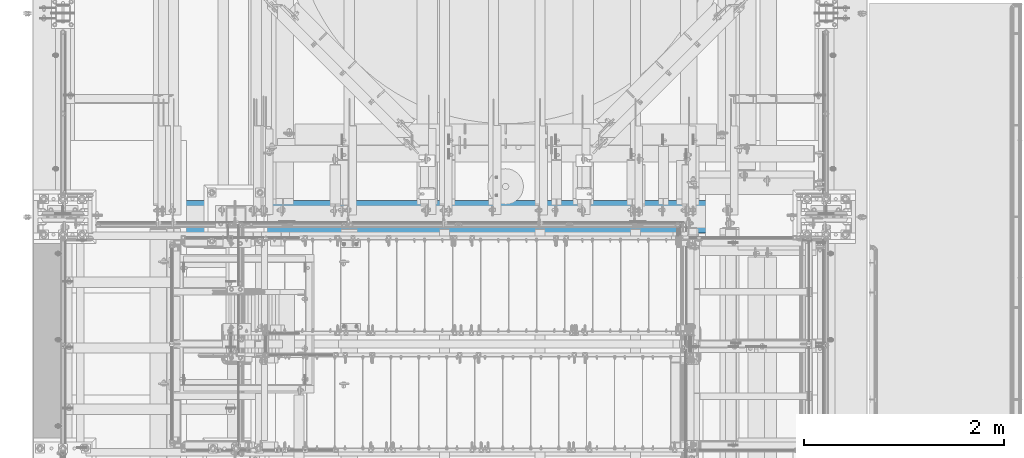
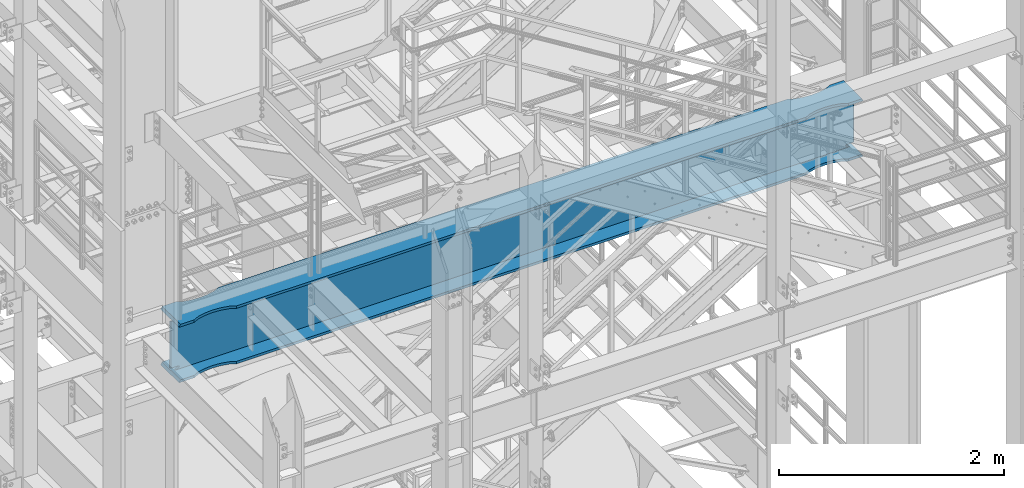
# One storey, part 980 of 1876: 1 beam, 1 element without a shape of its own.
"""IFC2X3 building model written with IfcOpenShell, lengths in millimetres."""

from ifc_helpers import new_model, si_unit, frame, origin_with_axes, place, context, subcontext, project, spatial, faceted_brep, material, type_object, element, aggregate, save


model = new_model("IFC2X3")

# Units and contexts
model_context = context("Model", 3, precision=1e-05, world=origin_with_axes())
body_context = subcontext(model_context, "Body", "Model", "MODEL_VIEW")
ifc_project = project(units=[si_unit("LENGTHUNIT", "METRE", prefix="MILLI"), si_unit("AREAUNIT", "SQUARE_METRE"), si_unit("VOLUMEUNIT", "CUBIC_METRE"), si_unit("MASSUNIT", "GRAM", prefix="KILO"), si_unit("TIMEUNIT", "SECOND"), si_unit("PLANEANGLEUNIT", "RADIAN"), si_unit("SOLIDANGLEUNIT", "STERADIAN"), si_unit("THERMODYNAMICTEMPERATUREUNIT", "DEGREE_CELSIUS"), si_unit("LUMINOUSINTENSITYUNIT", "LUMEN")], contexts=[model_context])

# Site, building, storey
site_placement = place(None, origin_with_axes())
site = spatial("IfcSite", under=ifc_project, at=site_placement, CompositionType="ELEMENT")
building_placement = place(site_placement, origin_with_axes())
building = spatial("IfcBuilding", under=site, at=building_placement, Name="Undefined", CompositionType="ELEMENT")
storey_placement = place(building_placement, origin_with_axes())
storey = spatial("IfcBuildingStorey", under=building, at=storey_placement, Name="Undefined", CompositionType="ELEMENT", Elevation=0.0)

# Assembly, beam
assembly_placement = place(storey_placement, origin_with_axes())
assembly = element("IfcElementAssembly", 1, at=assembly_placement, inside=storey, Name="BEAM", AssemblyPlace="NOTDEFINED", PredefinedType="RIGID_FRAME")
ifc_material = material(Name="STEEL/A992")
beam_type = type_object("IfcBeamType", Name="W24X146", PredefinedType="NOTDEFINED")
beam_placement = place(assembly_placement, frame((0.0, -4572.0, 12995.275), z_axis=(0.0, 0.0, 1.0), x_axis=(1.0, 0.0, 0.0)))
beam = element("IfcBeam", 2, at=beam_placement, type_object=beam_type, material=ifc_material, Name="BEAM", ObjectType="W24X146", context=body_context, shape_type="Brep", body=[
    faceted_brep([(301.625, 7.9375, -252.4125), (311.15, -7.9375, -252.4125), (311.15, -7.9375, 252.4125), (301.625, 7.9375, 252.4125), (7318.375, 7.9375, 252.4125), (7308.85, -7.9375, 252.4125), (7308.85, -7.9375, -252.4125), (7318.375, 7.9375, -252.4125), (7318.375, -163.5125, 287.3375), (7318.375, -7.9375, 287.3375), (7318.375, 7.9375, 287.3375), (7318.375, 163.5125, 287.3375), (7302.79342652469, 163.512500456442, 314.325000000001), (7302.79342652469, -163.512500199422, 314.325000000001), (7162.80000000007, 163.512504557366, 314.325000000001), (7162.80000000007, 163.5125, 287.3375), (7105.88894087753, 135.739157957359, 287.3375), (7105.88894087753, 135.739157957359, 314.325000000001), (7027.22389842007, 118.4990401514, 287.3375), (7027.22389842007, 118.4990401514, 314.325000000001), (6946.90001329237, 112.712500184298, 287.3375), (6946.90001329237, 112.712500184298, 314.325000000001), (6866.57612824297, 118.499041238055, 287.3375), (6866.57612824297, 118.499041238055, 314.325000000001), (6788.83917036842, 135.535762460966, 287.3375), (6788.83917036842, 135.535762460966, 314.325000000001), (6788.3806123108, 135.650670947547, 287.3375), (6788.3806123108, 135.650670947547, 314.325000000001), (6787.92970812774, 135.792674011595, 287.3375), (6787.92970812774, 135.792674011595, 314.325000000001), (6787.48805720929, 135.961267957882, 287.3375), (6787.48805720929, 135.961267957882, 314.325000000001), (6787.05722612347, 136.155854771378, 287.3375), (6787.05722612347, 136.155854771378, 314.325000000001), (6731.00000871499, 163.5125, 287.3375), (6731.00000871499, 163.512500299129, 314.325000000001), (888.999990590519, 163.5125, 287.3375), (888.999990590519, 163.512503274253, 314.325000000001), (832.088931467987, 135.739156674245, 287.3375), (832.088931467987, 135.739156674245, 314.325000000001), (753.423889010533, 118.499038868286, 287.3375), (753.423889010533, 118.499038868286, 314.325000000001), (673.100003882856, 112.712498901185, 287.3375), (673.100003882856, 112.712498901185, 314.325000000001), (592.776118833464, 118.499039954942, 287.3375), (592.776118833464, 118.499039954942, 314.325000000001), (515.039160958935, 135.535761177853, 287.3375), (515.039160958935, 135.535761177853, 314.325000000001), (514.580602901315, 135.650669664434, 287.3375), (514.580602901315, 135.650669664434, 314.325000000001), (514.12969871826, 135.792672728482, 287.3375), (514.12969871826, 135.792672728482, 314.325000000001), (513.688047799806, 135.961266674769, 287.3375), (513.688047799806, 135.961266674769, 314.325000000001), (513.257216713985, 136.155853488265, 287.3375), (513.257216713985, 136.155853488265, 314.325000000001), (457.199999305522, 163.5125, 287.3375), (457.199999305522, 163.5125, 314.325000000001), (301.625, 163.5125, 287.3375), (317.206573475306, 163.5125, 314.325000000001), (7162.80000000007, 163.512504557366, -287.3375), (7162.80000000007, 163.5125, -314.325000000001), (7105.88894087753, 135.739157957359, -314.325000000001), (7105.88894087753, 135.739157957359, -287.3375), (7027.22389842007, 118.4990401514, -314.325000000001), (7027.22389842007, 118.4990401514, -287.3375), (6946.90001329237, 112.712500184298, -314.325000000001), (6946.90001329237, 112.712500184298, -287.3375), (6866.57612824297, 118.499041238055, -314.325000000001), (6866.57612824297, 118.499041238055, -287.3375), (6788.83917036842, 135.535762460966, -314.325000000001), (6788.83917036842, 135.535762460966, -287.3375), (6788.3806123108, 135.650670947547, -314.325000000001), (6788.3806123108, 135.650670947547, -287.3375), (6787.92970812774, 135.792674011595, -314.325000000001), (6787.92970812774, 135.792674011595, -287.3375), (6787.48805720929, 135.961267957882, -314.325000000001), (6787.48805720929, 135.961267957882, -287.3375), (6787.05722612347, 136.155854771378, -314.325000000001), (6787.05722612347, 136.155854771378, -287.3375), (6731.00000871499, 163.5125, -314.325000000001), (6731.00000871499, 163.512500299129, -287.3375), (888.999990590519, 163.5125, -314.325000000001), (888.999990590519, 163.512503274253, -287.3375), (832.088931467987, 135.739156674245, -314.325000000001), (832.088931467987, 135.739156674245, -287.3375), (753.423889010533, 118.499038868286, -314.325000000001), (753.423889010533, 118.499038868286, -287.3375), (673.100003882856, 112.712498901185, -314.325000000001), (673.100003882856, 112.712498901185, -287.3375), (592.776118833464, 118.499039954942, -314.325000000001), (592.776118833464, 118.499039954942, -287.3375), (515.039160958935, 135.535761177853, -314.325000000001), (515.039160958935, 135.535761177853, -287.3375), (514.580602901315, 135.650669664434, -314.325000000001), (514.580602901315, 135.650669664434, -287.3375), (514.12969871826, 135.792672728482, -314.325000000001), (514.12969871826, 135.792672728482, -287.3375), (513.688047799806, 135.961266674769, -314.325000000001), (513.688047799806, 135.961266674769, -287.3375), (513.257216713985, 136.155853488265, -314.325000000001), (513.257216713985, 136.155853488265, -287.3375), (457.199999305522, 163.5125, -314.325000000001), (457.199999305522, 163.5125, -287.3375), (301.625, 163.5125, -314.325000000001), (317.206585323961, 163.5125, -287.3375), (7162.80000000007, -163.512501991139, -287.3375), (7105.88894087753, -135.739155391132, -287.3375), (7105.88894087753, -135.739155391132, -314.325000000001), (7162.80000000007, -163.5125, -314.325000000001), (7027.22389842007, -118.499037585173, -287.3375), (7027.22389842007, -118.499037585173, -314.325000000001), (6946.90001329237, -112.712497618071, -287.3375), (6946.90001329237, -112.712497618071, -314.325000000001), (6866.57612824297, -118.499038671828, -287.3375), (6866.57612824297, -118.499038671828, -314.325000000001), (6788.83917036842, -135.535759894739, -287.3375), (6788.83917036842, -135.535759894739, -314.325000000001), (6788.3806123108, -135.65066838132, -287.3375), (6788.3806123108, -135.65066838132, -314.325000000001), (6787.92970812774, -135.792671445369, -287.3375), (6787.92970812774, -135.792671445369, -314.325000000001), (6787.48805720929, -135.961265391656, -287.3375), (6787.48805720929, -135.961265391656, -314.325000000001), (6787.05722612347, -136.155852205152, -287.3375), (6787.05722612347, -136.155852205152, -314.325000000001), (6731.00000871499, -163.512500299129, -287.3375), (6731.00000871499, -163.5125, -314.325000000001), (888.999990590519, -163.512503274253, -287.3375), (888.999990590519, -163.5125, -314.325000000001), (832.088931467987, -135.739156674245, -287.3375), (832.088931467987, -135.739156674245, -314.325000000001), (753.423889010533, -118.499038868286, -287.3375), (753.423889010533, -118.499038868286, -314.325000000001), (673.100003882856, -112.712498901185, -287.3375), (673.100003882856, -112.712498901185, -314.325000000001), (592.776118833464, -118.499039954942, -287.3375), (592.776118833464, -118.499039954942, -314.325000000001), (515.039160958935, -135.535761177853, -287.3375), (515.039160958935, -135.535761177853, -314.325000000001), (514.580602901315, -135.650669664434, -287.3375), (514.580602901315, -135.650669664434, -314.325000000001), (514.12969871826, -135.792672728482, -287.3375), (514.12969871826, -135.792672728482, -314.325000000001), (513.688047799806, -135.961266674769, -287.3375), (513.688047799806, -135.961266674769, -314.325000000001), (513.257216713985, -136.155853488265, -287.3375), (513.257216713985, -136.155853488265, -314.325000000001), (457.199999305522, -163.5125, -287.3375), (457.199999305522, -163.5125, -314.325000000001), (317.206585323961, -163.5125, -287.3375), (301.625, -163.5125, -314.325000000001), (317.435792427282, -7.9375, -286.94049987793), (317.435792427282, 7.9375, -286.94049987793), (317.206585323961, 7.9375, -287.3375), (317.206585323961, -7.9375, -287.3375), (354.177996826172, -7.9375, -286.94049987793), (354.177996826172, 7.9375, -286.94049987793), (389.650251149281, -7.9375, -270.587562630286), (389.650251149281, 7.9375, -270.587562630286), (393.540459055476, -7.9375, -267.291342989443), (393.540459055476, 7.9375, -267.291342989443), (395.173124802588, -7.9375, -262.460899528196), (395.173124802588, 7.9375, -262.460899528196), (394.08038362386, -7.9375, -257.48046800167), (394.08038362386, 7.9375, -257.48046800167), (390.575376832887, -7.9375, -253.777265486369), (390.575376832887, 7.9375, -253.777265486369), (385.66251650093, -7.9375, -252.4125), (385.66251650093, 7.9375, -252.4125), (385.497515023773, -7.9375, 252.412500000002), (385.497515023773, 7.9375, 252.412500000002), (390.410375292523, -7.9375, 253.777265448314), (390.410375292523, 7.9375, 253.777265448314), (393.915382077658, -7.9375, 257.480467871263), (393.915382077658, 7.9375, 257.480467871263), (395.008123337595, -7.9375, 262.460899307192), (395.008123337595, 7.9375, 262.460899307192), (393.375457744202, -7.9375, 267.291342745357), (393.375457744202, 7.9375, 267.291342745357), (389.485250007137, -7.9375, 270.587562475845), (389.485250007137, 7.9375, 270.587562475845), (354.012998962403, -7.9375, 286.94049987793), (354.012998962403, 7.9375, 286.94049987793), (301.625, -7.9375, 286.94049987793), (301.625, 7.9375, 286.94049987793), (301.625, -7.9375, 287.3375), (301.625, 7.9375, 287.3375), (317.206573475306, -163.5125, 314.325000000001), (301.625, -163.5125, 287.3375), (457.199999305522, -163.5125, 287.3375), (457.199999305522, -163.5125, 314.325000000001), (513.257216713985, -136.155853488265, 287.3375), (513.257216713985, -136.155853488265, 314.325000000001), (513.688047799806, -135.961266674769, 287.3375), (513.688047799806, -135.961266674769, 314.325000000001), (514.12969871826, -135.792672728482, 287.3375), (514.12969871826, -135.792672728482, 314.325000000001), (514.580602901315, -135.650669664434, 287.3375), (514.580602901315, -135.650669664434, 314.325000000001), (515.039160958935, -135.535761177853, 287.3375), (515.039160958935, -135.535761177853, 314.325000000001), (592.776118833464, -118.499039954942, 287.3375), (592.776118833464, -118.499039954942, 314.325000000001), (673.100003882856, -112.712498901185, 287.3375), (673.100003882856, -112.712498901185, 314.325000000001), (753.423889010533, -118.499038868286, 287.3375), (753.423889010533, -118.499038868286, 314.325000000001), (832.088931467987, -135.739156674245, 287.3375), (832.088931467987, -135.739156674245, 314.325000000001), (888.999990590519, -163.512503274253, 314.325000000001), (888.999990590519, -163.5125, 287.3375), (6731.00000871499, -163.5125, 287.3375), (6731.00000871499, -163.512500299129, 314.325000000001), (6787.05722612347, -136.155852205152, 287.3375), (6787.05722612347, -136.155852205152, 314.325000000001), (6787.48805720929, -135.961265391656, 287.3375), (6787.48805720929, -135.961265391656, 314.325000000001), (6787.92970812774, -135.792671445369, 287.3375), (6787.92970812774, -135.792671445369, 314.325000000001), (6788.3806123108, -135.65066838132, 287.3375), (6788.3806123108, -135.65066838132, 314.325000000001), (6788.83917036842, -135.535759894739, 287.3375), (6788.83917036842, -135.535759894739, 314.325000000001), (6866.57612824297, -118.499038671828, 287.3375), (6866.57612824297, -118.499038671828, 314.325000000001), (6946.90001329237, -112.712497618071, 287.3375), (6946.90001329237, -112.712497618071, 314.325000000001), (7027.22389842007, -118.499037585173, 287.3375), (7027.22389842007, -118.499037585173, 314.325000000001), (7105.88894087753, -135.739155391132, 287.3375), (7105.88894087753, -135.739155391132, 314.325000000001), (7162.80000000007, -163.512501991139, 314.325000000001), (7162.80000000007, -163.5125, 287.3375), (7318.375, -7.9375, 286.94049987793), (7318.375, 7.9375, 286.94049987793), (7265.9870010376, -7.9375, 286.94049987793), (7265.9870010376, 7.9375, 286.94049987793), (7230.51474999286, -7.9375, 270.587562475843), (7230.51474999286, 7.9375, 270.587562475843), (7226.6245422558, -7.9375, 267.291342745357), (7226.6245422558, 7.9375, 267.291342745357), (7224.9918766624, -7.9375, 262.460899307192), (7224.9918766624, 7.9375, 262.460899307192), (7226.08461792234, -7.9375, 257.480467871263), (7226.08461792234, 7.9375, 257.480467871263), (7229.58962470748, -7.9375, 253.777265448316), (7229.58962470748, 7.9375, 253.777265448316), (7234.50248497622, -7.9375, 252.4125), (7234.50248497622, 7.9375, 252.4125), (7234.33748349907, -7.9375, -252.4125), (7234.33748349907, 7.9375, -252.4125), (7229.42462316711, -7.9375, -253.777265486369), (7229.42462316711, 7.9375, -253.777265486369), (7225.91961637614, -7.9375, -257.48046800167), (7225.91961637614, 7.9375, -257.48046800167), (7224.82687519741, -7.9375, -262.460899528196), (7224.82687519741, 7.9375, -262.460899528196), (7226.45954094452, -7.9375, -267.291342989443), (7226.45954094452, 7.9375, -267.291342989443), (7230.34974885072, -7.9375, -270.587562630286), (7230.34974885072, 7.9375, -270.587562630286), (7265.82200317383, -7.9375, -286.94049987793), (7265.82200317383, 7.9375, -286.94049987793), (7302.56420757272, -7.9375, -286.94049987793), (7302.56420757272, 7.9375, -286.94049987793), (7302.79341467604, 7.9375, -287.3375), (7302.79341467604, 163.512500456442, -287.3375), (7318.375, 163.5125, -314.325000000001), (7318.375, -163.5125, -314.325000000001), (7302.79341467604, -163.512500199422, -287.3375), (7302.79341467604, -7.9375, -287.3375)], [[[0, 1, 2, 3]], [[4, 5, 6, 7]], [[8, 9, 10, 11, 12, 13]], [[14, 15, 16, 17]], [[17, 16, 18, 19]], [[19, 18, 20, 21]], [[21, 20, 22, 23]], [[23, 22, 24, 25]], [[25, 24, 26, 27]], [[27, 26, 28, 29]], [[29, 28, 30, 31]], [[31, 30, 32, 33]], [[33, 32, 34, 35]], [[36, 37, 35, 34]], [[37, 36, 38, 39]], [[39, 38, 40, 41]], [[41, 40, 42, 43]], [[43, 42, 44, 45]], [[45, 44, 46, 47]], [[47, 46, 48, 49]], [[49, 48, 50, 51]], [[51, 50, 52, 53]], [[53, 52, 54, 55]], [[55, 54, 56, 57]], [[57, 56, 58, 59]], [[60, 61, 62, 63]], [[63, 62, 64, 65]], [[65, 64, 66, 67]], [[67, 66, 68, 69]], [[69, 68, 70, 71]], [[71, 70, 72, 73]], [[73, 72, 74, 75]], [[75, 74, 76, 77]], [[77, 76, 78, 79]], [[79, 78, 80, 81]], [[82, 83, 81, 80]], [[83, 82, 84, 85]], [[85, 84, 86, 87]], [[87, 86, 88, 89]], [[89, 88, 90, 91]], [[91, 90, 92, 93]], [[93, 92, 94, 95]], [[95, 94, 96, 97]], [[97, 96, 98, 99]], [[99, 98, 100, 101]], [[101, 100, 102, 103]], [[103, 102, 104, 105]], [[106, 107, 108, 109]], [[110, 111, 108, 107]], [[112, 113, 111, 110]], [[114, 115, 113, 112]], [[116, 117, 115, 114]], [[118, 119, 117, 116]], [[120, 121, 119, 118]], [[122, 123, 121, 120]], [[124, 125, 123, 122]], [[126, 127, 125, 124]], [[128, 129, 127, 126]], [[128, 130, 131, 129]], [[132, 133, 131, 130]], [[134, 135, 133, 132]], [[136, 137, 135, 134]], [[138, 139, 137, 136]], [[140, 141, 139, 138]], [[142, 143, 141, 140]], [[144, 145, 143, 142]], [[146, 147, 145, 144]], [[148, 149, 147, 146]], [[149, 148, 150, 151]], [[152, 153, 154, 105, 104, 151, 150, 155]], [[156, 157, 153, 152]], [[158, 159, 157, 156]], [[160, 161, 159, 158]], [[162, 163, 161, 160]], [[164, 165, 163, 162]], [[166, 167, 165, 164]], [[168, 169, 167, 166]], [[169, 168, 1, 0]], [[170, 171, 3, 2]], [[172, 173, 171, 170]], [[174, 175, 173, 172]], [[176, 177, 175, 174]], [[178, 179, 177, 176]], [[180, 181, 179, 178]], [[182, 183, 181, 180]], [[183, 182, 184, 185]], [[185, 184, 186, 187]], [[188, 59, 58, 187, 186, 189]], [[190, 191, 188, 189]], [[191, 190, 192, 193]], [[193, 192, 194, 195]], [[195, 194, 196, 197]], [[197, 196, 198, 199]], [[199, 198, 200, 201]], [[201, 200, 202, 203]], [[203, 202, 204, 205]], [[205, 204, 206, 207]], [[207, 206, 208, 209]], [[210, 209, 208, 211]], [[210, 211, 212, 213]], [[213, 212, 214, 215]], [[215, 214, 216, 217]], [[217, 216, 218, 219]], [[219, 218, 220, 221]], [[221, 220, 222, 223]], [[223, 222, 224, 225]], [[225, 224, 226, 227]], [[227, 226, 228, 229]], [[229, 228, 230, 231]], [[232, 231, 230, 233]], [[232, 233, 8, 13]], [[14, 17, 19, 21, 23, 25, 27, 29, 31, 33, 35, 37, 39, 41, 43, 45, 47, 49, 51, 53, 55, 57, 59, 188, 191, 193, 195, 197, 199, 201, 203, 205, 207, 209, 210, 213, 215, 217, 219, 221, 223, 225, 227, 229, 231, 232, 13, 12]], [[15, 14, 12, 11]], [[187, 58, 56, 54, 52, 50, 48, 46, 44, 42, 40, 38, 36, 34, 32, 30, 28, 26, 24, 22, 20, 18, 16, 15, 11, 10]], [[234, 235, 10, 9]], [[236, 237, 235, 234]], [[238, 239, 237, 236]], [[240, 241, 239, 238]], [[242, 243, 241, 240]], [[244, 245, 243, 242]], [[246, 247, 245, 244]], [[248, 249, 247, 246]], [[249, 248, 5, 4]], [[250, 251, 7, 6]], [[252, 253, 251, 250]], [[254, 255, 253, 252]], [[256, 257, 255, 254]], [[258, 259, 257, 256]], [[260, 261, 259, 258]], [[262, 263, 261, 260]], [[263, 262, 264, 265]], [[154, 153, 157, 159, 161, 163, 165, 167, 169, 0, 3, 171, 173, 175, 177, 179, 181, 183, 185, 187, 10, 235, 237, 239, 241, 243, 245, 247, 249, 4, 7, 251, 253, 255, 257, 259, 261, 263, 265, 266]], [[60, 63, 65, 67, 69, 71, 73, 75, 77, 79, 81, 83, 85, 87, 89, 91, 93, 95, 97, 99, 101, 103, 105, 154, 266, 267]], [[61, 60, 267, 268]], [[109, 108, 111, 113, 115, 117, 119, 121, 123, 125, 127, 129, 131, 133, 135, 137, 139, 141, 143, 145, 147, 149, 151, 104, 102, 100, 98, 96, 94, 92, 90, 88, 86, 84, 82, 80, 78, 76, 74, 72, 70, 68, 66, 64, 62, 61, 268, 269]], [[106, 109, 269, 270]], [[155, 150, 148, 146, 144, 142, 140, 138, 136, 134, 132, 130, 128, 126, 124, 122, 120, 118, 116, 114, 112, 110, 107, 106, 270, 271]], [[269, 268, 267, 266, 265, 264, 271, 270]], [[168, 166, 164, 162, 160, 158, 156, 152, 155, 271, 264, 262, 260, 258, 256, 254, 252, 250, 6, 5, 248, 246, 244, 242, 240, 238, 236, 234, 9, 186, 184, 182, 180, 178, 176, 174, 172, 170, 2, 1]], [[233, 230, 228, 226, 224, 222, 220, 218, 216, 214, 212, 211, 208, 206, 204, 202, 200, 198, 196, 194, 192, 190, 189, 186, 9, 8]]]),
])
aggregate(assembly, [beam])

save(model, "model.ifc")
